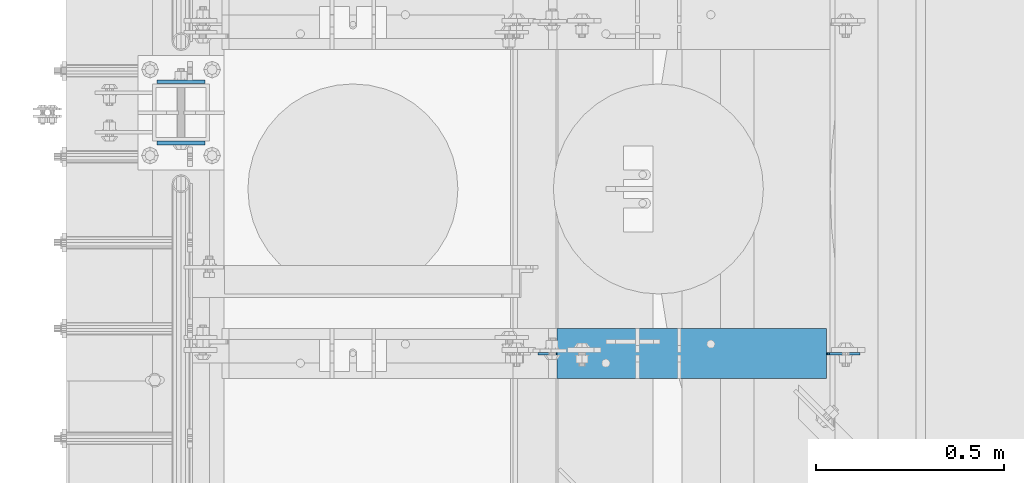
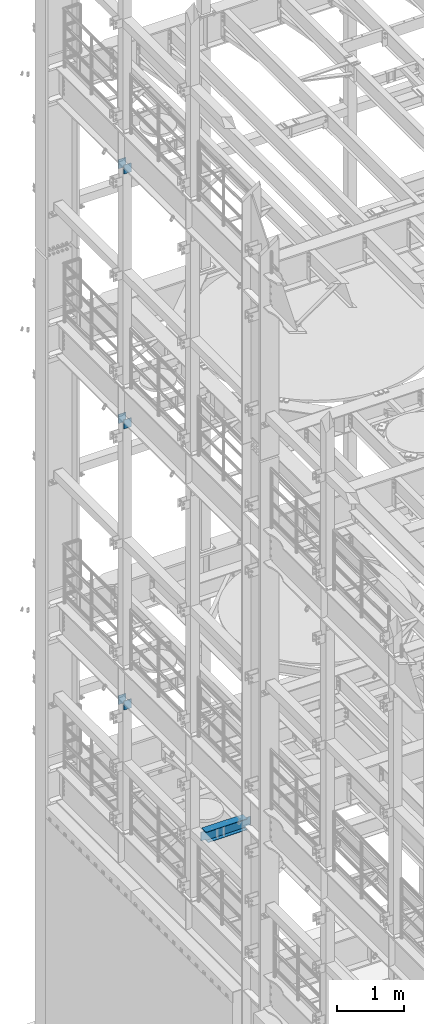
# One storey, part 1305 of 1876: 7 beams, 4 elements without a shape of their own.
"""IFC2X3 building model written with IfcOpenShell, lengths in millimetres."""

from ifc_helpers import new_model, si_unit, frame, origin_with_axes, place, context, subcontext, project, spatial, faceted_brep, material, type_object, element, aggregate, save


model = new_model("IFC2X3")

# Units and contexts
model_context = context("Model", 3, precision=1e-05, world=origin_with_axes())
body_context = subcontext(model_context, "Body", "Model", "MODEL_VIEW")
ifc_project = project(units=[si_unit("LENGTHUNIT", "METRE", prefix="MILLI"), si_unit("AREAUNIT", "SQUARE_METRE"), si_unit("VOLUMEUNIT", "CUBIC_METRE"), si_unit("MASSUNIT", "GRAM", prefix="KILO"), si_unit("TIMEUNIT", "SECOND"), si_unit("PLANEANGLEUNIT", "RADIAN"), si_unit("SOLIDANGLEUNIT", "STERADIAN"), si_unit("THERMODYNAMICTEMPERATUREUNIT", "DEGREE_CELSIUS"), si_unit("LUMINOUSINTENSITYUNIT", "LUMEN")], contexts=[model_context])

# Site, building, storey
site_placement = place(None, origin_with_axes())
site = spatial("IfcSite", under=ifc_project, at=site_placement, CompositionType="ELEMENT")
building_placement = place(site_placement, origin_with_axes())
building = spatial("IfcBuilding", under=site, at=building_placement, Name="Undefined", CompositionType="ELEMENT")
storey_placement = place(building_placement, origin_with_axes())
storey = spatial("IfcBuildingStorey", under=building, at=storey_placement, Name="Undefined", CompositionType="ELEMENT", Elevation=0.0)

# Assembly, beams
assembly_1_placement = place(storey_placement, origin_with_axes())
assembly_1 = element("IfcElementAssembly", 1, at=assembly_1_placement, inside=storey, Name="BEAM", AssemblyPlace="NOTDEFINED", PredefinedType="RIGID_FRAME")
ifc_material_1 = material(Name="STEEL/A36")
beam_type_1 = type_object("IfcBeamType", PredefinedType="NOTDEFINED")
beam_1_placement = place(assembly_1_placement, frame((-63.6296757345187, 11766.55, 7448.54714244377), z_axis=(5.59490000219896e-05, 0.0, -0.999999998434855), x_axis=(0.999999998434855, 0.0, 5.59490000219868e-05)))
beam_1 = element("IfcBeam", 2, at=beam_1_placement, type_object=beam_type_1, material=ifc_material_1, Name="PLATE", context=body_context, shape_type="Brep", body=[
    faceted_brep([(0.0, 4.76249999999982, -82.5499999999993), (0.0, 4.76249999999982, 82.5499999999993), (127.0, 4.76249999999982, 82.5499999999993), (127.0, 4.76249999999982, -82.5499999999993), (0.0, -4.76249999999982, 82.5499999999993), (127.0, -4.76249999999982, 82.5499999999993), (0.0, -4.76249999999982, -82.5499999999993), (127.0, -4.76249999999982, -82.5499999999993)], [[[0, 1, 2, 3]], [[1, 4, 5, 2]], [[4, 6, 7, 5]], [[6, 0, 3, 7]], [[5, 7, 3, 2]], [[6, 4, 1, 0]]]),
])
beam_2_placement = place(assembly_1_placement, frame((-63.6296757345187, 11603.0375, 7448.54714244377), z_axis=(5.59490000219896e-05, 0.0, -0.999999998434855), x_axis=(0.999999998434855, 0.0, 5.59490000219868e-05)))
beam_2 = element("IfcBeam", 3, at=beam_2_placement, type_object=beam_type_1, material=ifc_material_1, Name="PLATE", context=body_context, shape_type="Brep", body=[
    faceted_brep([(0.0, 4.76249999999982, -82.5499999999993), (0.0, 4.76249999999982, 82.5499999999993), (127.0, 4.76249999999982, 82.5499999999993), (127.0, 4.76249999999982, -82.5499999999993), (0.0, -4.76249999999982, 82.5499999999993), (127.0, -4.76249999999982, 82.5499999999993), (0.0, -4.76249999999982, -82.5499999999993), (127.0, -4.76249999999982, -82.5499999999993)], [[[0, 1, 2, 3]], [[1, 4, 5, 2]], [[4, 6, 7, 5]], [[6, 0, 3, 7]], [[5, 7, 3, 2]], [[6, 4, 1, 0]]]),
])
aggregate(assembly_1, [beam_1, beam_2])

assembly_2_placement = place(storey_placement, origin_with_axes())
assembly_2 = element("IfcElementAssembly", 4, at=assembly_2_placement, inside=storey, Name="BEAM", AssemblyPlace="NOTDEFINED", PredefinedType="RIGID_FRAME")
beam_3_placement = place(assembly_2_placement, frame((-63.6315195800257, 11766.55, 12604.7488224823), z_axis=(2.95459999824743e-05, 0.0, -0.999999999563517), x_axis=(0.999999999563517, 0.0, 2.95459999828704e-05)))
beam_3 = element("IfcBeam", 5, at=beam_3_placement, type_object=beam_type_1, material=ifc_material_1, Name="PLATE", context=body_context, shape_type="Brep", body=[
    faceted_brep([(0.0, 4.76249999999982, -82.5499999999993), (0.0, 4.76249999999982, 82.5499999999993), (127.0, 4.76249999999982, 82.5499999999993), (127.0, 4.76249999999982, -82.5499999999993), (0.0, -4.76249999999982, 82.5499999999993), (127.0, -4.76249999999982, 82.5499999999993), (0.0, -4.76249999999982, -82.5499999999993), (127.0, -4.76249999999982, -82.5499999999993)], [[[0, 1, 2, 3]], [[1, 4, 5, 2]], [[4, 6, 7, 5]], [[6, 0, 3, 7]], [[5, 7, 3, 2]], [[6, 4, 1, 0]]]),
])
beam_4_placement = place(assembly_2_placement, frame((-63.6315195800257, 11603.0375, 12604.7488224823), z_axis=(2.95459999824743e-05, 0.0, -0.999999999563517), x_axis=(0.999999999563517, 0.0, 2.95459999828704e-05)))
beam_4 = element("IfcBeam", 6, at=beam_4_placement, type_object=beam_type_1, material=ifc_material_1, Name="PLATE", context=body_context, shape_type="Brep", body=[
    faceted_brep([(0.0, 4.76249999999982, -82.5499999999993), (0.0, 4.76249999999982, 82.5499999999993), (127.0, 4.76249999999982, 82.5499999999993), (127.0, 4.76249999999982, -82.5499999999993), (0.0, -4.76249999999982, 82.5499999999993), (127.0, -4.76249999999982, 82.5499999999993), (0.0, -4.76249999999982, -82.5499999999993), (127.0, -4.76249999999982, -82.5499999999993)], [[[0, 1, 2, 3]], [[1, 4, 5, 2]], [[4, 6, 7, 5]], [[6, 0, 3, 7]], [[5, 7, 3, 2]], [[6, 4, 1, 0]]]),
])
aggregate(assembly_2, [beam_3, beam_4])

assembly_3_placement = place(storey_placement, origin_with_axes())
assembly_3 = element("IfcElementAssembly", 7, at=assembly_3_placement, inside=storey, Name="BEAM", AssemblyPlace="NOTDEFINED", PredefinedType="RIGID_FRAME")
beam_5_placement = place(assembly_3_placement, frame((-63.5, 11766.55, 17278.35), z_axis=(0.0, 0.0, -1.0), x_axis=(1.0, 0.0, 0.0)))
beam_5 = element("IfcBeam", 8, at=beam_5_placement, type_object=beam_type_1, material=ifc_material_1, Name="PLATE", context=body_context, shape_type="Brep", body=[
    faceted_brep([(0.0, 4.76249999999982, -82.5499999999993), (0.0, 4.76249999999982, 82.5499999999993), (127.0, 4.76249999999982, 82.5499999999993), (127.0, 4.76249999999982, -82.5499999999993), (0.0, -4.76249999999982, 82.5499999999993), (127.0, -4.76249999999982, 82.5499999999993), (0.0, -4.76249999999982, -82.5499999999993), (127.0, -4.76249999999982, -82.5499999999993)], [[[0, 1, 2, 3]], [[1, 4, 5, 2]], [[4, 6, 7, 5]], [[6, 0, 3, 7]], [[5, 7, 3, 2]], [[6, 4, 1, 0]]]),
])
beam_6_placement = place(assembly_3_placement, frame((-63.5, 11603.0375, 17278.35), z_axis=(0.0, 0.0, -1.0), x_axis=(1.0, 0.0, 0.0)))
beam_6 = element("IfcBeam", 9, at=beam_6_placement, type_object=beam_type_1, material=ifc_material_1, Name="PLATE", context=body_context, shape_type="Brep", body=[
    faceted_brep([(0.0, 4.76249999999982, -82.5499999999993), (0.0, 4.76249999999982, 82.5499999999993), (127.0, 4.76249999999982, 82.5499999999993), (127.0, 4.76249999999982, -82.5499999999993), (0.0, -4.76249999999982, 82.5499999999993), (127.0, -4.76249999999982, 82.5499999999993), (0.0, -4.76249999999982, -82.5499999999993), (127.0, -4.76249999999982, -82.5499999999993)], [[[0, 1, 2, 3]], [[1, 4, 5, 2]], [[4, 6, 7, 5]], [[6, 0, 3, 7]], [[5, 7, 3, 2]], [[6, 4, 1, 0]]]),
])
aggregate(assembly_3, [beam_5, beam_6])

# Assembly, beam
assembly_4_placement = place(storey_placement, origin_with_axes())
assembly_4 = element("IfcElementAssembly", 10, at=assembly_4_placement, inside=storey, Name="BEAM", AssemblyPlace="NOTDEFINED", PredefinedType="RIGID_FRAME")
ifc_material_2 = material(Name="STEEL/A992")
beam_type_2 = type_object("IfcBeamType", Name="W8X18", PredefinedType="NOTDEFINED")
beam_7_placement = place(assembly_4_placement, frame((730.25, 11042.65, 5027.6125), z_axis=(0.0, 0.0, 1.0), x_axis=(1.0, 0.0, 0.0)))
beam_7 = element("IfcBeam", 11, at=beam_7_placement, type_object=beam_type_2, material=ifc_material_2, Name="BEAM", ObjectType="W8X18", context=body_context, shape_type="Brep", body=[
    faceted_brep([(219.075, -3.17499999999927, -77.7875000000013), (219.075, 3.17499999999927, -77.7875000000013), (295.275000190735, 3.17499999999927, -77.7875000000013), (295.275000190735, -3.17499999999927, -77.7875000000013), (300.13507970878, 3.17499999999927, -78.7542299225888), (300.13507970878, -3.17499999999927, -78.7542299225888), (304.255256176934, 3.17499999999927, -81.5072438230673), (304.255256176934, -3.17499999999927, -81.5072438230673), (307.008270077412, 3.17499999999927, -85.6274202912209), (307.008270077412, -3.17499999999927, -85.6274202912209), (307.975, -3.17499999999927, -90.4874998092664), (307.975, 3.17499999999927, -90.4874998092664), (307.975, 3.17499999999927, -95.25), (307.975, 66.6749999999993, -95.25), (307.975, 66.6749999999993, -103.1875), (307.975, -66.6749999999993, -103.1875), (307.975, -66.6749999999993, -95.25), (307.975, -3.17499999999927, -95.25), (269.875, -66.6749999999993, 103.1875), (269.875, 66.6749999999993, 103.1875), (269.875, 66.6749999999993, 96.837499809264), (269.875, -66.6749999999993, 96.837499809264), (269.559226654725, 3.17499999999927, 95.25), (269.559226654725, 66.6749999999993, 95.25), (987.424999999997, 66.6749999999993, 95.25), (987.424999999997, 3.17499999999927, 95.25), (257.175000190735, -3.17499999999927, 84.1374999999989), (257.175000190735, 3.17499999999927, 84.1374999999989), (219.075, 3.17499999999927, 84.1374999999989), (219.075, -3.17499999999927, 84.1374999999989), (262.03507970878, -3.17499999999927, 85.1042299225865), (262.03507970878, 3.17499999999927, 85.1042299225865), (266.155256176934, -3.17499999999927, 87.8572438230649), (266.155256176934, 3.17499999999927, 87.8572438230649), (268.908270077412, -3.17499999999927, 91.9774202912186), (268.908270077412, 3.17499999999927, 91.9774202912186), (269.559226654725, -3.17499999999927, 95.25), (269.559226654725, -66.6749999999993, 95.25), (987.424999999997, -3.17499999999927, 95.25), (987.424999999997, -66.6749999999993, 95.25), (987.424999999997, -66.6749999999993, 103.1875), (987.424999999997, 66.6749999999993, 103.1875), (987.424999999997, -3.17499999999927, 90.4874998092664), (987.424999999997, 3.17499999999927, 90.4874998092664), (988.391729922585, -3.17499999999927, 85.6274202912209), (988.391729922585, 3.17499999999927, 85.6274202912209), (991.144743823063, -3.17499999999927, 81.5072438230673), (991.144743823063, 3.17499999999927, 81.5072438230673), (995.264920291217, -3.17499999999927, 78.7542299225888), (995.264920291217, 3.17499999999927, 78.7542299225888), (1000.125, -3.17500000000018, 77.7875000000013), (1000.125, 3.17500000000018, 77.7875000000013), (1076.325, -3.17500000000018, 77.7874999999985), (1076.325, 3.17500000000018, 77.7874999999985), (1076.325, -3.17500000000018, -77.7874999999985), (1076.325, 3.17500000000018, -77.7874999999985), (1000.125, -3.17500000000018, -77.7875000000013), (1000.125, 3.17500000000018, -77.7875000000013), (995.264920291217, -3.17499999999927, -78.7542299225861), (995.264920291217, 3.17499999999927, -78.7542299225861), (991.144743823063, -3.17499999999927, -81.5072438230645), (991.144743823063, 3.17499999999927, -81.5072438230645), (988.391729922585, -3.17499999999927, -85.6274202912182), (988.391729922585, 3.17499999999927, -85.6274202912182), (987.424999999997, -3.17499999999927, -90.4874998092637), (987.424999999997, 3.17499999999927, -90.4874998092637), (987.424999999997, -3.17499999999927, -95.25), (987.424999999997, -66.6749999999993, -95.25), (987.424999999997, -66.6749999999993, -103.1875), (987.424999999997, 66.6749999999993, -103.1875), (987.424999999997, 66.6749999999993, -95.25), (987.424999999997, 3.17499999999927, -95.25)], [[[0, 1, 2, 3]], [[3, 2, 4, 5]], [[5, 4, 6, 7]], [[7, 6, 8, 9]], [[10, 11, 12, 13, 14, 15, 16, 17]], [[9, 8, 11, 10]], [[18, 19, 20, 21]], [[22, 23, 24, 25]], [[26, 27, 28, 29]], [[30, 31, 27, 26]], [[32, 33, 31, 30]], [[34, 35, 33, 32]], [[21, 20, 23, 22, 35, 34, 36, 37]], [[37, 36, 38, 39]], [[18, 21, 37, 39, 40]], [[19, 18, 40, 41]], [[23, 20, 19, 41, 24]], [[40, 39, 38, 42, 43, 25, 24, 41]], [[44, 45, 43, 42]], [[46, 47, 45, 44]], [[48, 49, 47, 46]], [[50, 51, 49, 48]], [[52, 53, 51, 50]], [[53, 52, 54, 55]], [[54, 56, 57, 55]], [[58, 59, 57, 56]], [[60, 61, 59, 58]], [[62, 63, 61, 60]], [[64, 65, 63, 62]], [[66, 67, 68, 69, 70, 71, 65, 64]], [[67, 66, 17, 16]], [[68, 67, 16, 15]], [[69, 68, 15, 14]], [[70, 69, 14, 13]], [[71, 70, 13, 12]], [[6, 4, 2, 1, 28, 27, 31, 33, 35, 22, 25, 43, 45, 47, 49, 51, 53, 55, 57, 59, 61, 63, 65, 71, 12, 11, 8]], [[29, 28, 1, 0]], [[66, 64, 62, 60, 58, 56, 54, 52, 50, 48, 46, 44, 42, 38, 36, 34, 32, 30, 26, 29, 0, 3, 5, 7, 9, 10, 17]]]),
])
aggregate(assembly_4, [beam_7])

save(model, "model.ifc")
